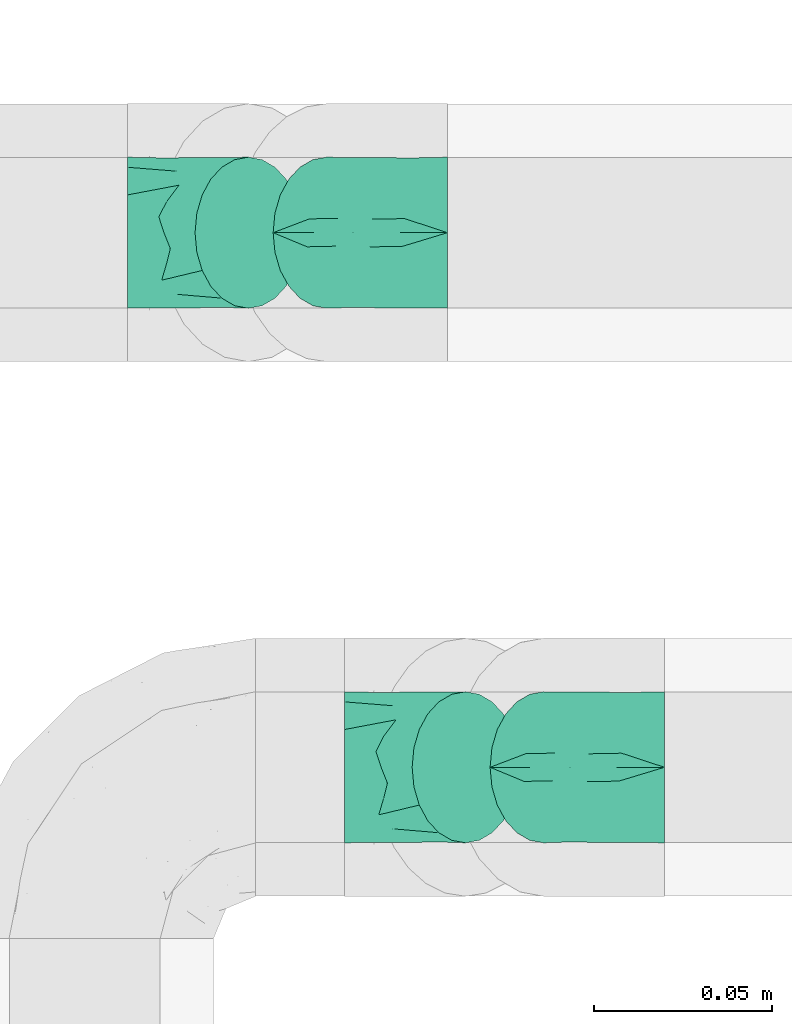
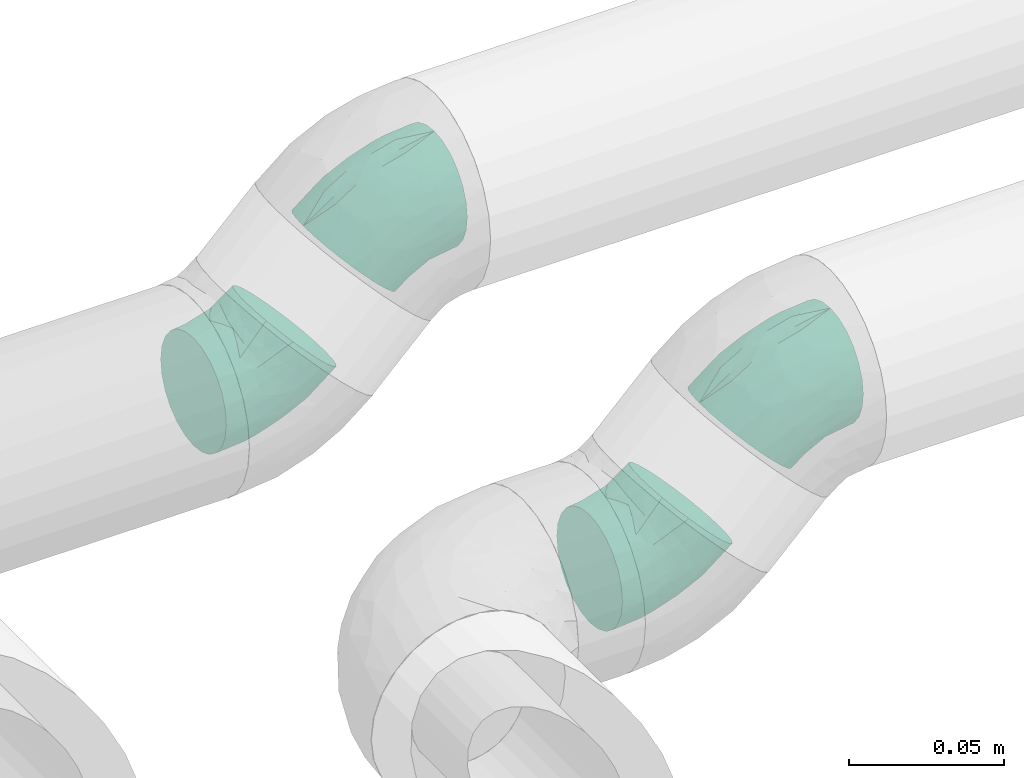
# One storey, part 38 of 39: 4 flow fittings.
"""IFC2X3 building model written with IfcOpenShell, lengths in millimetres."""

from ifc_helpers import new_model, entity, si_unit, converted_unit, derived_unit, direction, frame, origin, place, context, subcontext, project, spatial, faceted_brep, source, transform, mapped, material, type_object, type_shapes, element, save


model = new_model("IFC2X3")

# Units and contexts
model_context = context("Model", 3, precision=0.01, world=origin(), true_north=direction((6.12303176911189e-17, 1.0)))
body_context = subcontext(model_context, "Body", "Model", "MODEL_VIEW")
ifc_project = project(units=[si_unit("LENGTHUNIT", "METRE", prefix="MILLI"), si_unit("AREAUNIT", "SQUARE_METRE"), si_unit("VOLUMEUNIT", "CUBIC_METRE"), converted_unit("PLANEANGLEUNIT", "DEGREE", entity("IfcRatioMeasure", 0.0174532925199433), si_unit("PLANEANGLEUNIT", "RADIAN"), dimensions=[0, 0, 0, 0, 0, 0, 0]), si_unit("MASSUNIT", "GRAM", prefix="KILO"), derived_unit("MASSDENSITYUNIT", [(si_unit("MASSUNIT", "GRAM", prefix="KILO"), 1), (si_unit("LENGTHUNIT", "METRE"), -3)]), derived_unit("MOMENTOFINERTIAUNIT", [(si_unit("LENGTHUNIT", "METRE"), 4)]), si_unit("TIMEUNIT", "SECOND"), si_unit("FREQUENCYUNIT", "HERTZ"), si_unit("THERMODYNAMICTEMPERATUREUNIT", "DEGREE_CELSIUS"), derived_unit("THERMALTRANSMITTANCEUNIT", [(si_unit("MASSUNIT", "GRAM", prefix="KILO"), 1), (si_unit("THERMODYNAMICTEMPERATUREUNIT", "KELVIN"), -1), (si_unit("TIMEUNIT", "SECOND"), -3)]), derived_unit("VOLUMETRICFLOWRATEUNIT", [(si_unit("LENGTHUNIT", "METRE"), 3), (si_unit("TIMEUNIT", "SECOND"), -1)]), derived_unit("MASSFLOWRATEUNIT", [(si_unit("MASSUNIT", "GRAM", prefix="KILO"), 1), (si_unit("TIMEUNIT", "SECOND"), -1)]), derived_unit("ROTATIONALFREQUENCYUNIT", [(si_unit("TIMEUNIT", "SECOND"), -1)]), si_unit("ELECTRICCURRENTUNIT", "AMPERE"), si_unit("ELECTRICVOLTAGEUNIT", "VOLT"), si_unit("POWERUNIT", "WATT"), si_unit("FORCEUNIT", "NEWTON", prefix="KILO"), si_unit("ILLUMINANCEUNIT", "LUX"), si_unit("LUMINOUSFLUXUNIT", "LUMEN"), si_unit("LUMINOUSINTENSITYUNIT", "CANDELA"), derived_unit("USERDEFINED", [(si_unit("MASSUNIT", "GRAM", prefix="KILO"), -1), (si_unit("LENGTHUNIT", "METRE"), -2), (si_unit("TIMEUNIT", "SECOND"), 3), (si_unit("LUMINOUSFLUXUNIT", "LUMEN"), 1)]), derived_unit("LINEARVELOCITYUNIT", [(si_unit("LENGTHUNIT", "METRE"), 1), (si_unit("TIMEUNIT", "SECOND"), -1)]), si_unit("PRESSUREUNIT", "PASCAL"), derived_unit("USERDEFINED", [(si_unit("LENGTHUNIT", "METRE"), -2), (si_unit("MASSUNIT", "GRAM", prefix="KILO"), 1), (si_unit("TIMEUNIT", "SECOND"), -2)]), derived_unit("LINEARFORCEUNIT", [(si_unit("MASSUNIT", "GRAM", prefix="KILO"), 1), (si_unit("LENGTHUNIT", "METRE"), 1), (si_unit("TIMEUNIT", "SECOND"), -2), (si_unit("LENGTHUNIT", "METRE"), -1)]), derived_unit("PLANARFORCEUNIT", [(si_unit("MASSUNIT", "GRAM", prefix="KILO"), 1), (si_unit("LENGTHUNIT", "METRE"), 1), (si_unit("TIMEUNIT", "SECOND"), -2), (si_unit("LENGTHUNIT", "METRE"), -2)])], contexts=[model_context])

# Site, building, storey
site_placement = place(None, origin())
site = spatial("IfcSite", under=ifc_project, at=site_placement, CompositionType="ELEMENT")
building_placement = place(site_placement, origin())
building = spatial("IfcBuilding", under=site, at=building_placement, CompositionType="ELEMENT")
storey_placement = place(building_placement, frame((0.0, 0.0, 24000.0)))
storey = spatial("IfcBuildingStorey", under=building, at=storey_placement, Name="07", CompositionType="ELEMENT", Elevation=24000.0)

# Flow fittings
ifc_material = material()
pipe_fitting_type_1 = type_object("IfcPipeFittingType", Name="ADSK_1", PredefinedType="NOTDEFINED", material=ifc_material)
shared_shape_1 = source(origin(), body_context, "Body", "Brep", [
    faceted_brep([(-19.88, 10.6, -18.36), (-19.88, 5.49, -20.48), (-19.88, 0.0, -21.2), (-19.88, -5.49, -20.48), (-19.88, -10.6, -18.36), (-19.88, -14.99, -14.99), (-19.88, -18.36, -10.6), (-19.88, -20.48, -5.49), (-19.88, -21.2, 0.0), (-19.88, -20.48, 5.49), (-19.88, -18.36, 10.6), (-19.88, -14.99, 14.99), (-19.88, -10.6, 18.36), (-19.88, -5.49, 20.48), (-19.88, 0.0, 21.2), (-19.88, 5.49, 20.48), (-19.88, 10.6, 18.36), (-19.88, 14.99, 14.99), (-19.88, 18.36, 10.6), (-19.88, 20.48, 5.49), (-19.88, 21.2, 0.0), (-19.88, 20.48, -5.49), (-19.88, 18.36, -10.6), (-19.88, 14.99, -14.99), (14.06, 14.06, -21.2), (10.18, 17.94, -20.48), (6.56, 21.55, -18.36), (3.46, 24.66, -14.99), (1.08, 27.04, -10.6), (-0.42, 28.54, -5.49), (-0.93, 29.05, 0.0), (-0.42, 28.54, 5.49), (1.08, 27.04, 10.6), (3.46, 24.66, 14.99), (6.56, 21.55, 18.36), (10.18, 17.94, 20.48), (14.06, 14.06, 21.2), (17.94, 10.18, 20.48), (21.55, 6.56, 18.36), (24.66, 3.46, 14.99), (27.04, 1.08, 10.6), (28.54, -0.42, 5.49), (29.05, -0.93, 0.0), (28.54, -0.42, -5.49), (27.04, 1.08, -10.6), (24.66, 3.46, -14.99), (21.55, 6.56, -18.36), (17.94, 10.18, -20.48), (-7.98, -16.04, 12.48), (1.95, -4.7, 19.17), (-9.77, -7.63, 19.4), (-5.58, -11.73, 16.42), (16.99, -5.7, 12.48), (-7.22, -1.78, 20.93), (-9.05, 9.07, 19.79), (-2.24, 5.4, 21.12), (-11.98, 3.07, 21.07), (1.16, 13.58, 19.77), (4.62, 11.03, 20.88), (-4.7, -18.12, 7.46), (5.18, -12.51, 11.97), (12.3, 1.51, 19.4), (-8.92, 21.52, 8.68), (-10.28, 17.98, 13.33), (-6.22, 15.02, 17.27), (11.52, -13.28, 3.78), (6.03, -14.57, 7.78), (1.86, -17.3, 3.96), (-6.64, -18.57, 0.0), (-6.99, -19.62, 3.9), (19.51, -8.44, 3.96), (16.13, -9.49, 7.46), (-7.85, 23.53, 4.44), (-3.2, 19.54, 14.97), (6.36, 3.85, 20.93), (12.24, -4.35, 16.42), (6.6, -15.93, 0.0), (-9.63, 23.24, 0.0), (3.3, -7.97, 17.06), (17.82, -8.43, 0.0), (-7.22, -1.78, -20.93), (1.24, -17.54, -3.78), (6.03, -14.57, -7.78), (10.92, -13.55, -3.96), (-0.01, 12.81, -19.79), (-10.42, 8.78, -19.77), (-11.06, 4.53, -20.88), (-5.45, 19.99, -13.33), (-11.55, 16.08, -14.97), (12.24, -4.35, -16.42), (16.13, -9.49, -7.46), (-11.09, 22.19, -4.44), (-8.92, 21.52, -8.68), (6.36, 3.85, -20.93), (-7.83, -19.76, -3.96), (-4.7, -18.12, -7.46), (-7.98, -16.04, -12.48), (5.18, -12.51, -11.97), (-5.58, -11.73, -16.42), (3.3, -7.97, -17.06), (-9.77, -7.63, -19.4), (1.95, -4.7, -19.17), (-6.22, 15.02, -17.27), (18.82, -8.93, -3.9), (6.3, 10.64, -21.07), (12.3, 1.51, -19.4), (16.99, -5.7, -12.48), (-2.24, 5.4, -21.12)], [[[0, 1, 2, 3, 4, 5, 6, 7, 8, 9, 10, 11, 12, 13, 14, 15, 16, 17, 18, 19, 20, 21, 22, 23]], [[24, 25, 26, 27, 28, 29, 30, 31, 32, 33, 34, 35, 36, 37, 38, 39, 40, 41, 42, 43, 44, 45, 46, 47]], [[10, 48, 11]], [[49, 50, 51]], [[12, 11, 51]], [[40, 39, 52]], [[14, 13, 53]], [[13, 12, 50]], [[16, 15, 54]], [[55, 56, 53]], [[14, 56, 15]], [[35, 57, 58]], [[48, 59, 60]], [[38, 37, 61]], [[62, 18, 63]], [[64, 17, 16]], [[65, 66, 67]], [[68, 67, 69]], [[70, 71, 65]], [[62, 72, 19]], [[10, 9, 59]], [[20, 19, 72]], [[19, 18, 62]], [[48, 51, 11]], [[54, 64, 16]], [[59, 66, 60]], [[8, 68, 69]], [[33, 73, 34]], [[36, 58, 74]], [[39, 38, 75]], [[49, 74, 53]], [[74, 37, 36]], [[67, 68, 76]], [[71, 40, 52]], [[55, 58, 57]], [[75, 38, 61]], [[59, 48, 10]], [[65, 71, 66]], [[41, 70, 42]], [[56, 54, 15]], [[72, 62, 31]], [[77, 72, 30]], [[52, 75, 60]], [[51, 78, 49]], [[49, 61, 74]], [[35, 34, 57]], [[32, 31, 62]], [[62, 63, 32]], [[50, 53, 13]], [[32, 63, 73]], [[64, 54, 57]], [[18, 17, 63]], [[55, 53, 74]], [[41, 40, 71]], [[51, 48, 60]], [[78, 60, 75]], [[75, 52, 39]], [[71, 52, 60]], [[17, 64, 63]], [[73, 63, 64]], [[64, 57, 34]], [[55, 57, 54]], [[51, 50, 12]], [[53, 50, 49]], [[74, 61, 37]], [[75, 61, 49]], [[74, 58, 55]], [[36, 35, 58]], [[53, 56, 14]], [[54, 56, 55]], [[67, 66, 59]], [[71, 60, 66]], [[67, 59, 69]], [[67, 76, 65]], [[76, 79, 65]], [[70, 65, 79]], [[42, 70, 79]], [[41, 71, 70]], [[59, 9, 69]], [[8, 69, 9]], [[60, 78, 51]], [[75, 49, 78]], [[30, 72, 31]], [[72, 77, 20]], [[34, 73, 64]], [[32, 73, 33]], [[3, 2, 80]], [[81, 82, 83]], [[26, 25, 84]], [[1, 85, 86]], [[87, 88, 22]], [[46, 45, 89]], [[0, 23, 88]], [[44, 43, 90]], [[21, 91, 92]], [[24, 47, 93]], [[94, 95, 81]], [[1, 0, 85]], [[81, 95, 82]], [[95, 96, 97]], [[7, 94, 8]], [[96, 95, 6]], [[5, 4, 98]], [[99, 97, 98]], [[7, 6, 95]], [[5, 96, 6]], [[100, 4, 3]], [[28, 27, 87]], [[83, 79, 76]], [[89, 99, 101]], [[20, 77, 91]], [[98, 96, 5]], [[30, 29, 91]], [[29, 28, 92]], [[22, 92, 87]], [[92, 22, 21]], [[28, 87, 92]], [[100, 98, 4]], [[84, 102, 26]], [[102, 84, 85]], [[86, 80, 2]], [[27, 26, 102]], [[79, 83, 103]], [[24, 104, 25]], [[105, 47, 46]], [[90, 82, 97]], [[106, 89, 45]], [[89, 101, 105]], [[90, 97, 106]], [[101, 80, 93]], [[42, 79, 103]], [[101, 100, 80]], [[107, 93, 80]], [[106, 45, 44]], [[96, 98, 97]], [[104, 93, 107]], [[104, 84, 25]], [[29, 92, 91]], [[107, 86, 85]], [[105, 93, 47]], [[90, 106, 44]], [[89, 106, 97]], [[27, 102, 87]], [[88, 87, 102]], [[102, 85, 0]], [[107, 85, 84]], [[80, 100, 3]], [[98, 100, 101]], [[89, 105, 46]], [[93, 105, 101]], [[80, 86, 107]], [[2, 1, 86]], [[93, 104, 24]], [[84, 104, 107]], [[83, 82, 90]], [[95, 97, 82]], [[83, 90, 103]], [[83, 76, 81]], [[76, 68, 81]], [[94, 81, 68]], [[8, 94, 68]], [[7, 95, 94]], [[90, 43, 103]], [[42, 103, 43]], [[97, 99, 89]], [[98, 101, 99]], [[20, 91, 21]], [[91, 77, 30]], [[0, 88, 102]], [[22, 88, 23]]]),
])
type_shapes(pipe_fitting_type_1, [shared_shape_1])
flow_fitting_1_placement = place(storey_placement, frame((68762.89, 2725.35, 3029.96), z_axis=(0.0, -1.0, 0.0), x_axis=(1.0, 0.0, 1.53605279146355e-05)))
element("IfcFlowFitting", 1, at=flow_fitting_1_placement, inside=storey, type_object=pipe_fitting_type_1, material=ifc_material, Name="ADSK_1", ObjectType="ADSK_1", context=body_context, shape_type="MappedRepresentation", body=[
    mapped(shared_shape_1, transform((0.0, 0.0, 0.0), scale=1.0)),
])
pipe_fitting_type_2 = type_object("IfcPipeFittingType", Name="ADSK_1", PredefinedType="NOTDEFINED", material=ifc_material)
shared_shape_2 = source(origin(), body_context, "Body", "Brep", [
    faceted_brep([(-19.88, 10.6, -18.36), (-19.88, 5.49, -20.48), (-19.88, 0.0, -21.2), (-19.88, -5.49, -20.48), (-19.88, -10.6, -18.36), (-19.88, -14.99, -14.99), (-19.88, -18.36, -10.6), (-19.88, -20.48, -5.49), (-19.88, -21.2, 0.0), (-19.88, -20.48, 5.49), (-19.88, -18.36, 10.6), (-19.88, -14.99, 14.99), (-19.88, -10.6, 18.36), (-19.88, -5.49, 20.48), (-19.88, 0.0, 21.2), (-19.88, 5.49, 20.48), (-19.88, 10.6, 18.36), (-19.88, 14.99, 14.99), (-19.88, 18.36, 10.6), (-19.88, 20.48, 5.49), (-19.88, 21.2, 0.0), (-19.88, 20.48, -5.49), (-19.88, 18.36, -10.6), (-19.88, 14.99, -14.99), (1.08, 27.04, -10.6), (-0.42, 28.54, -5.49), (-0.93, 29.05, 0.0), (-0.42, 28.54, 5.49), (1.08, 27.04, 10.6), (3.46, 24.66, 14.99), (6.56, 21.55, 18.36), (10.18, 17.94, 20.48), (14.06, 14.06, 21.2), (17.94, 10.17, 20.48), (21.55, 6.56, 18.36), (24.66, 3.45, 14.99), (27.04, 1.07, 10.6), (28.54, -0.43, 5.49), (29.05, -0.94, 0.0), (28.54, -0.43, -5.49), (27.04, 1.07, -10.6), (24.66, 3.45, -14.99), (21.55, 6.56, -18.36), (17.94, 10.17, -20.48), (14.06, 14.06, -21.2), (10.18, 17.94, -20.48), (6.56, 21.55, -18.36), (3.46, 24.66, -14.99), (-7.98, -16.04, 12.48), (1.95, -4.7, 19.17), (-9.77, -7.63, 19.4), (-5.58, -11.73, 16.42), (16.99, -5.7, 12.48), (-7.22, -1.78, 20.93), (-9.05, 9.07, 19.79), (-2.23, 5.4, 21.12), (-11.98, 3.07, 21.07), (1.16, 13.58, 19.77), (4.61, 11.03, 20.88), (-4.69, -18.12, 7.46), (5.18, -12.51, 11.97), (12.3, 1.51, 19.4), (-8.91, 21.52, 8.68), (-10.28, 17.98, 13.33), (-6.22, 15.02, 17.26), (11.53, -13.28, 3.78), (6.03, -14.57, 7.78), (1.86, -17.3, 3.96), (-6.64, -18.57, 0.0), (-6.99, -19.62, 3.9), (19.51, -8.44, 3.96), (16.13, -9.5, 7.46), (-7.85, 23.53, 4.44), (-3.2, 19.54, 14.97), (6.36, 3.85, 20.93), (12.23, -4.35, 16.42), (6.6, -15.93, 0.0), (-9.62, 23.24, 0.0), (3.3, -7.97, 17.06), (17.82, -8.44, 0.0), (-7.22, -1.78, -20.93), (1.24, -17.54, -3.78), (6.03, -14.57, -7.78), (10.92, -13.55, -3.96), (-0.01, 12.81, -19.79), (-10.42, 8.78, -19.77), (-11.06, 4.53, -20.88), (-5.45, 19.99, -13.33), (-11.55, 16.08, -14.97), (12.23, -4.35, -16.42), (16.13, -9.5, -7.46), (-11.09, 22.19, -4.44), (-8.91, 21.52, -8.68), (6.36, 3.85, -20.93), (-7.83, -19.76, -3.96), (-4.69, -18.12, -7.46), (-7.98, -16.04, -12.48), (5.18, -12.51, -11.97), (-5.58, -11.73, -16.42), (3.3, -7.97, -17.06), (-9.77, -7.63, -19.4), (1.95, -4.7, -19.17), (-6.22, 15.02, -17.26), (18.82, -8.93, -3.9), (6.3, 10.64, -21.07), (12.3, 1.51, -19.4), (16.99, -5.7, -12.48), (-2.23, 5.4, -21.12)], [[[0, 1, 2, 3, 4, 5, 6, 7, 8, 9, 10, 11, 12, 13, 14, 15, 16, 17, 18, 19, 20, 21, 22, 23]], [[24, 25, 26, 27, 28, 29, 30, 31, 32, 33, 34, 35, 36, 37, 38, 39, 40, 41, 42, 43, 44, 45, 46, 47]], [[10, 48, 11]], [[49, 50, 51]], [[12, 11, 51]], [[36, 35, 52]], [[14, 13, 53]], [[13, 12, 50]], [[16, 15, 54]], [[55, 56, 53]], [[14, 56, 15]], [[31, 57, 58]], [[48, 59, 60]], [[34, 33, 61]], [[62, 18, 63]], [[64, 17, 16]], [[65, 66, 67]], [[68, 67, 69]], [[70, 71, 65]], [[62, 72, 19]], [[10, 9, 59]], [[20, 19, 72]], [[19, 18, 62]], [[48, 51, 11]], [[54, 64, 16]], [[59, 66, 60]], [[8, 68, 69]], [[29, 73, 30]], [[32, 58, 74]], [[35, 34, 75]], [[49, 74, 53]], [[74, 33, 32]], [[67, 68, 76]], [[71, 36, 52]], [[55, 58, 57]], [[75, 34, 61]], [[59, 48, 10]], [[65, 71, 66]], [[37, 70, 38]], [[56, 54, 15]], [[72, 62, 27]], [[77, 72, 26]], [[52, 75, 60]], [[51, 78, 49]], [[49, 61, 74]], [[31, 30, 57]], [[28, 27, 62]], [[62, 63, 28]], [[50, 53, 13]], [[28, 63, 73]], [[64, 54, 57]], [[18, 17, 63]], [[55, 53, 74]], [[37, 36, 71]], [[51, 48, 60]], [[78, 60, 75]], [[75, 52, 35]], [[71, 52, 60]], [[17, 64, 63]], [[73, 63, 64]], [[64, 57, 30]], [[55, 57, 54]], [[51, 50, 12]], [[53, 50, 49]], [[74, 61, 33]], [[75, 61, 49]], [[74, 58, 55]], [[32, 31, 58]], [[53, 56, 14]], [[54, 56, 55]], [[67, 66, 59]], [[71, 60, 66]], [[67, 59, 69]], [[67, 76, 65]], [[76, 79, 65]], [[70, 65, 79]], [[38, 70, 79]], [[37, 71, 70]], [[59, 9, 69]], [[8, 69, 9]], [[60, 78, 51]], [[75, 49, 78]], [[26, 72, 27]], [[72, 77, 20]], [[30, 73, 64]], [[28, 73, 29]], [[3, 2, 80]], [[81, 82, 83]], [[46, 45, 84]], [[1, 85, 86]], [[87, 88, 22]], [[42, 41, 89]], [[0, 23, 88]], [[40, 39, 90]], [[21, 91, 92]], [[44, 43, 93]], [[94, 95, 81]], [[1, 0, 85]], [[81, 95, 82]], [[95, 96, 97]], [[7, 94, 8]], [[96, 95, 6]], [[5, 4, 98]], [[99, 97, 98]], [[7, 6, 95]], [[5, 96, 6]], [[100, 4, 3]], [[24, 47, 87]], [[83, 79, 76]], [[89, 99, 101]], [[20, 77, 91]], [[98, 96, 5]], [[26, 25, 91]], [[25, 24, 92]], [[22, 92, 87]], [[92, 22, 21]], [[24, 87, 92]], [[100, 98, 4]], [[84, 102, 46]], [[102, 84, 85]], [[86, 80, 2]], [[47, 46, 102]], [[79, 83, 103]], [[44, 104, 45]], [[105, 43, 42]], [[90, 82, 97]], [[106, 89, 41]], [[89, 101, 105]], [[90, 97, 106]], [[101, 80, 93]], [[38, 79, 103]], [[101, 100, 80]], [[107, 93, 80]], [[106, 41, 40]], [[96, 98, 97]], [[104, 93, 107]], [[104, 84, 45]], [[25, 92, 91]], [[107, 86, 85]], [[105, 93, 43]], [[90, 106, 40]], [[89, 106, 97]], [[47, 102, 87]], [[88, 87, 102]], [[102, 85, 0]], [[107, 85, 84]], [[80, 100, 3]], [[98, 100, 101]], [[89, 105, 42]], [[93, 105, 101]], [[80, 86, 107]], [[2, 1, 86]], [[93, 104, 44]], [[84, 104, 107]], [[83, 82, 90]], [[95, 97, 82]], [[83, 90, 103]], [[83, 76, 81]], [[76, 68, 81]], [[94, 81, 68]], [[8, 94, 68]], [[7, 95, 94]], [[90, 39, 103]], [[38, 103, 39]], [[97, 99, 89]], [[98, 101, 99]], [[20, 91, 21]], [[91, 77, 26]], [[0, 88, 102]], [[22, 88, 23]]]),
])
type_shapes(pipe_fitting_type_2, [shared_shape_2])
flow_fitting_2_placement = place(storey_placement, frame((68752.01, 2875.35, 3080.0), z_axis=(0.0, -1.0, -2.11826697593205e-05), x_axis=(-1.0, 0.0, 0.0)))
element("IfcFlowFitting", 2, at=flow_fitting_2_placement, inside=storey, type_object=pipe_fitting_type_2, material=ifc_material, Name="ADSK_1", ObjectType="ADSK_1", context=body_context, shape_type="MappedRepresentation", body=[
    mapped(shared_shape_2, transform((0.0, 0.0, 0.0), scale=1.0)),
])
pipe_fitting_type_3 = type_object("IfcPipeFittingType", Name="ADSK_1", PredefinedType="NOTDEFINED", material=ifc_material)
shared_shape_3 = source(origin(), body_context, "Body", "Brep", [
    faceted_brep([(-19.89, 10.6, -18.36), (-19.89, 5.49, -20.48), (-19.89, 0.0, -21.2), (-19.89, -5.49, -20.48), (-19.89, -10.6, -18.36), (-19.89, -14.99, -14.99), (-19.89, -18.36, -10.6), (-19.89, -20.48, -5.49), (-19.89, -21.2, 0.0), (-19.89, -20.48, 5.49), (-19.89, -18.36, 10.6), (-19.89, -14.99, 14.99), (-19.89, -10.6, 18.36), (-19.89, -5.49, 20.48), (-19.89, 0.0, 21.2), (-19.89, 5.49, 20.48), (-19.89, 10.6, 18.36), (-19.89, 14.99, 14.99), (-19.89, 18.36, 10.6), (-19.89, 20.48, 5.49), (-19.89, 21.2, 0.0), (-19.89, 20.48, -5.49), (-19.89, 18.36, -10.6), (-19.89, 14.99, -14.99), (14.06, 14.06, -21.2), (10.18, 17.94, -20.48), (6.56, 21.56, -18.36), (3.46, 24.66, -14.99), (1.08, 27.04, -10.6), (-0.42, 28.54, -5.49), (-0.93, 29.05, 0.0), (-0.42, 28.54, 5.49), (1.08, 27.04, 10.6), (3.46, 24.66, 14.99), (6.56, 21.56, 18.36), (10.18, 17.94, 20.48), (14.06, 14.06, 21.2), (17.94, 10.18, 20.48), (21.56, 6.57, 18.36), (24.66, 3.46, 14.99), (27.04, 1.08, 10.6), (28.54, -0.42, 5.49), (29.05, -0.93, 0.0), (28.54, -0.42, -5.49), (27.04, 1.08, -10.6), (24.66, 3.46, -14.99), (21.56, 6.57, -18.36), (17.94, 10.18, -20.48), (-7.98, -16.04, 12.48), (1.95, -4.7, 19.17), (-9.77, -7.63, 19.4), (-5.58, -11.72, 16.42), (16.99, -5.7, 12.48), (-7.22, -1.78, 20.93), (-9.06, 9.07, 19.79), (-2.24, 5.4, 21.12), (-11.99, 3.07, 21.07), (1.16, 13.58, 19.77), (4.62, 11.03, 20.88), (-4.7, -18.12, 7.46), (5.18, -12.51, 11.97), (12.3, 1.52, 19.4), (-8.92, 21.52, 8.68), (-10.29, 17.98, 13.33), (-6.22, 15.02, 17.27), (11.52, -13.28, 3.78), (6.03, -14.57, 7.78), (1.85, -17.3, 3.96), (-6.64, -18.57, 0.0), (-6.99, -19.62, 3.9), (19.5, -8.44, 3.95), (16.14, -9.49, 7.46), (-7.85, 23.53, 4.44), (-3.2, 19.54, 14.97), (6.36, 3.85, 20.93), (12.24, -4.34, 16.42), (6.6, -15.93, 0.0), (-9.63, 23.24, 0.0), (3.3, -7.97, 17.06), (17.83, -8.43, 0.0), (-7.22, -1.78, -20.93), (1.25, -17.54, -3.78), (6.03, -14.57, -7.78), (10.93, -13.55, -3.96), (-0.01, 12.82, -19.79), (-10.42, 8.78, -19.77), (-11.06, 4.53, -20.88), (-5.45, 19.99, -13.33), (-11.56, 16.08, -14.97), (12.24, -4.34, -16.42), (16.14, -9.49, -7.46), (-11.09, 22.19, -4.44), (-8.92, 21.52, -8.68), (6.36, 3.85, -20.93), (-7.82, -19.76, -3.95), (-4.7, -18.12, -7.46), (-7.98, -16.04, -12.48), (5.18, -12.51, -11.97), (-5.58, -11.72, -16.42), (3.3, -7.97, -17.06), (-9.77, -7.63, -19.4), (1.95, -4.7, -19.17), (-6.22, 15.02, -17.27), (18.82, -8.93, -3.9), (6.3, 10.65, -21.07), (12.3, 1.52, -19.4), (16.99, -5.7, -12.48), (-2.24, 5.4, -21.12)], [[[0, 1, 2, 3, 4, 5, 6, 7, 8, 9, 10, 11, 12, 13, 14, 15, 16, 17, 18, 19, 20, 21, 22, 23]], [[24, 25, 26, 27, 28, 29, 30, 31, 32, 33, 34, 35, 36, 37, 38, 39, 40, 41, 42, 43, 44, 45, 46, 47]], [[10, 48, 11]], [[49, 50, 51]], [[12, 11, 51]], [[40, 39, 52]], [[14, 13, 53]], [[13, 12, 50]], [[16, 15, 54]], [[55, 56, 53]], [[14, 56, 15]], [[35, 57, 58]], [[48, 59, 60]], [[38, 37, 61]], [[62, 18, 63]], [[64, 17, 16]], [[65, 66, 67]], [[68, 67, 69]], [[70, 71, 65]], [[62, 72, 19]], [[10, 9, 59]], [[20, 19, 72]], [[19, 18, 62]], [[48, 51, 11]], [[54, 64, 16]], [[59, 66, 60]], [[8, 68, 69]], [[33, 73, 34]], [[36, 58, 74]], [[39, 38, 75]], [[49, 74, 53]], [[74, 37, 36]], [[67, 68, 76]], [[71, 40, 52]], [[55, 58, 57]], [[75, 38, 61]], [[59, 48, 10]], [[65, 71, 66]], [[41, 70, 42]], [[56, 54, 15]], [[72, 62, 31]], [[77, 72, 30]], [[52, 75, 60]], [[51, 78, 49]], [[49, 61, 74]], [[35, 34, 57]], [[32, 31, 62]], [[62, 63, 32]], [[50, 53, 13]], [[32, 63, 73]], [[64, 54, 57]], [[18, 17, 63]], [[55, 53, 74]], [[41, 40, 71]], [[51, 48, 60]], [[78, 60, 75]], [[75, 52, 39]], [[71, 52, 60]], [[17, 64, 63]], [[73, 63, 64]], [[64, 57, 34]], [[55, 57, 54]], [[51, 50, 12]], [[53, 50, 49]], [[74, 61, 37]], [[75, 61, 49]], [[74, 58, 55]], [[36, 35, 58]], [[53, 56, 14]], [[54, 56, 55]], [[67, 66, 59]], [[71, 60, 66]], [[67, 59, 69]], [[67, 76, 65]], [[76, 79, 65]], [[70, 65, 79]], [[42, 70, 79]], [[41, 71, 70]], [[59, 9, 69]], [[8, 69, 9]], [[60, 78, 51]], [[75, 49, 78]], [[30, 72, 31]], [[72, 77, 20]], [[34, 73, 64]], [[32, 73, 33]], [[3, 2, 80]], [[81, 82, 83]], [[26, 25, 84]], [[1, 85, 86]], [[87, 88, 22]], [[46, 45, 89]], [[0, 23, 88]], [[44, 43, 90]], [[21, 91, 92]], [[24, 47, 93]], [[94, 95, 81]], [[1, 0, 85]], [[81, 95, 82]], [[95, 96, 97]], [[7, 94, 8]], [[96, 95, 6]], [[5, 4, 98]], [[99, 97, 98]], [[7, 6, 95]], [[5, 96, 6]], [[100, 4, 3]], [[28, 27, 87]], [[83, 79, 76]], [[89, 99, 101]], [[20, 77, 91]], [[98, 96, 5]], [[30, 29, 91]], [[29, 28, 92]], [[22, 92, 87]], [[92, 22, 21]], [[28, 87, 92]], [[100, 98, 4]], [[84, 102, 26]], [[102, 84, 85]], [[86, 80, 2]], [[27, 26, 102]], [[79, 83, 103]], [[24, 104, 25]], [[105, 47, 46]], [[90, 82, 97]], [[106, 89, 45]], [[89, 101, 105]], [[90, 97, 106]], [[101, 80, 93]], [[42, 79, 103]], [[101, 100, 80]], [[107, 93, 80]], [[106, 45, 44]], [[96, 98, 97]], [[104, 93, 107]], [[104, 84, 25]], [[29, 92, 91]], [[107, 86, 85]], [[105, 93, 47]], [[90, 106, 44]], [[89, 106, 97]], [[27, 102, 87]], [[88, 87, 102]], [[102, 85, 0]], [[107, 85, 84]], [[80, 100, 3]], [[98, 100, 101]], [[89, 105, 46]], [[93, 105, 101]], [[80, 86, 107]], [[2, 1, 86]], [[93, 104, 24]], [[84, 104, 107]], [[83, 82, 90]], [[95, 97, 82]], [[83, 90, 103]], [[83, 76, 81]], [[76, 68, 81]], [[94, 81, 68]], [[8, 94, 68]], [[7, 95, 94]], [[90, 43, 103]], [[42, 103, 43]], [[97, 99, 89]], [[98, 101, 99]], [[20, 91, 21]], [[91, 77, 30]], [[0, 88, 102]], [[22, 88, 23]]]),
])
type_shapes(pipe_fitting_type_3, [shared_shape_3])
flow_fitting_3_placement = place(storey_placement, frame((68701.97, 2875.35, 3029.97), z_axis=(2.11779484984438e-05, 1.0, 0.0), x_axis=(-0.707185586519068, 1.49767399077523e-05, -0.707027966911762)))
element("IfcFlowFitting", 3, at=flow_fitting_3_placement, inside=storey, type_object=pipe_fitting_type_3, material=ifc_material, Name="ADSK_1", ObjectType="ADSK_1", context=body_context, shape_type="MappedRepresentation", body=[
    mapped(shared_shape_3, transform((0.0, 0.0, 0.0), scale=1.0)),
])
pipe_fitting_type_4 = type_object("IfcPipeFittingType", Name="ADSK_1", PredefinedType="NOTDEFINED", material=ifc_material)
shared_shape_4 = source(origin(), body_context, "Body", "Brep", [
    faceted_brep([(-19.88, 10.6, -18.36), (-19.88, 5.49, -20.48), (-19.88, 0.0, -21.2), (-19.88, -5.49, -20.48), (-19.88, -10.6, -18.36), (-19.88, -14.99, -14.99), (-19.88, -18.36, -10.6), (-19.88, -20.48, -5.49), (-19.88, -21.2, 0.0), (-19.88, -20.48, 5.49), (-19.88, -18.36, 10.6), (-19.88, -14.99, 14.99), (-19.88, -10.6, 18.36), (-19.88, -5.49, 20.48), (-19.88, 0.0, 21.2), (-19.88, 5.49, 20.48), (-19.88, 10.6, 18.36), (-19.88, 14.99, 14.99), (-19.88, 18.36, 10.6), (-19.88, 20.48, 5.49), (-19.88, 21.2, 0.0), (-19.88, 20.48, -5.49), (-19.88, 18.36, -10.6), (-19.88, 14.99, -14.99), (-0.42, 28.54, -5.49), (-0.93, 29.05, 0.0), (-0.42, 28.54, 5.49), (1.08, 27.04, 10.6), (3.46, 24.66, 14.99), (6.56, 21.55, 18.36), (10.18, 17.94, 20.48), (14.06, 14.06, 21.2), (17.94, 10.18, 20.48), (21.55, 6.56, 18.36), (24.66, 3.46, 14.99), (27.04, 1.08, 10.6), (28.54, -0.42, 5.49), (29.05, -0.93, 0.0), (28.54, -0.42, -5.49), (27.04, 1.08, -10.6), (24.66, 3.46, -14.99), (21.55, 6.56, -18.36), (17.94, 10.18, -20.48), (14.06, 14.06, -21.2), (10.18, 17.94, -20.48), (6.56, 21.55, -18.36), (3.46, 24.66, -14.99), (1.08, 27.04, -10.6), (-7.98, -16.04, 12.48), (1.95, -4.7, 19.17), (-9.77, -7.63, 19.4), (-5.58, -11.73, 16.42), (16.99, -5.7, 12.48), (-7.22, -1.78, 20.93), (-9.05, 9.07, 19.79), (-2.24, 5.4, 21.12), (-11.98, 3.07, 21.07), (1.16, 13.58, 19.77), (4.62, 11.03, 20.88), (-4.7, -18.12, 7.46), (5.18, -12.51, 11.97), (12.3, 1.51, 19.4), (-8.92, 21.52, 8.68), (-10.28, 17.98, 13.33), (-6.22, 15.02, 17.27), (11.52, -13.28, 3.78), (6.03, -14.57, 7.78), (1.86, -17.3, 3.96), (-6.64, -18.57, 0.0), (-6.99, -19.62, 3.9), (19.51, -8.44, 3.96), (16.13, -9.49, 7.46), (-7.85, 23.53, 4.44), (-3.2, 19.54, 14.97), (6.36, 3.85, 20.93), (12.24, -4.35, 16.42), (6.6, -15.93, 0.0), (-9.63, 23.24, 0.0), (3.3, -7.97, 17.06), (17.82, -8.43, 0.0), (-7.22, -1.78, -20.93), (1.24, -17.54, -3.78), (6.03, -14.57, -7.78), (10.92, -13.55, -3.96), (-0.01, 12.81, -19.79), (-10.42, 8.78, -19.77), (-11.06, 4.53, -20.88), (-5.45, 19.99, -13.33), (-11.55, 16.08, -14.97), (12.24, -4.35, -16.42), (16.13, -9.49, -7.46), (-11.09, 22.19, -4.44), (-8.92, 21.52, -8.68), (6.36, 3.85, -20.93), (-7.83, -19.76, -3.96), (-4.7, -18.12, -7.46), (-7.98, -16.04, -12.48), (5.18, -12.51, -11.97), (-5.58, -11.73, -16.42), (3.3, -7.97, -17.06), (-9.77, -7.63, -19.4), (1.95, -4.7, -19.17), (-6.22, 15.02, -17.27), (18.82, -8.93, -3.9), (6.3, 10.64, -21.07), (12.3, 1.51, -19.4), (16.99, -5.7, -12.48), (-2.24, 5.4, -21.12)], [[[0, 1, 2, 3, 4, 5, 6, 7, 8, 9, 10, 11, 12, 13, 14, 15, 16, 17, 18, 19, 20, 21, 22, 23]], [[24, 25, 26, 27, 28, 29, 30, 31, 32, 33, 34, 35, 36, 37, 38, 39, 40, 41, 42, 43, 44, 45, 46, 47]], [[10, 48, 11]], [[49, 50, 51]], [[12, 11, 51]], [[35, 34, 52]], [[14, 13, 53]], [[13, 12, 50]], [[16, 15, 54]], [[55, 56, 53]], [[14, 56, 15]], [[30, 57, 58]], [[48, 59, 60]], [[33, 32, 61]], [[62, 18, 63]], [[64, 17, 16]], [[65, 66, 67]], [[68, 67, 69]], [[70, 71, 65]], [[62, 72, 19]], [[10, 9, 59]], [[20, 19, 72]], [[19, 18, 62]], [[48, 51, 11]], [[54, 64, 16]], [[59, 66, 60]], [[8, 68, 69]], [[28, 73, 29]], [[31, 58, 74]], [[34, 33, 75]], [[49, 74, 53]], [[74, 32, 31]], [[67, 68, 76]], [[71, 35, 52]], [[55, 58, 57]], [[75, 33, 61]], [[59, 48, 10]], [[65, 71, 66]], [[36, 70, 37]], [[56, 54, 15]], [[72, 62, 26]], [[77, 72, 25]], [[52, 75, 60]], [[51, 78, 49]], [[49, 61, 74]], [[30, 29, 57]], [[27, 26, 62]], [[62, 63, 27]], [[50, 53, 13]], [[27, 63, 73]], [[64, 54, 57]], [[18, 17, 63]], [[55, 53, 74]], [[36, 35, 71]], [[51, 48, 60]], [[78, 60, 75]], [[75, 52, 34]], [[71, 52, 60]], [[17, 64, 63]], [[73, 63, 64]], [[64, 57, 29]], [[55, 57, 54]], [[51, 50, 12]], [[53, 50, 49]], [[74, 61, 32]], [[75, 61, 49]], [[74, 58, 55]], [[31, 30, 58]], [[53, 56, 14]], [[54, 56, 55]], [[67, 66, 59]], [[71, 60, 66]], [[67, 59, 69]], [[67, 76, 65]], [[76, 79, 65]], [[70, 65, 79]], [[37, 70, 79]], [[36, 71, 70]], [[59, 9, 69]], [[8, 69, 9]], [[60, 78, 51]], [[75, 49, 78]], [[25, 72, 26]], [[72, 77, 20]], [[29, 73, 64]], [[27, 73, 28]], [[3, 2, 80]], [[81, 82, 83]], [[45, 44, 84]], [[1, 85, 86]], [[87, 88, 22]], [[41, 40, 89]], [[0, 23, 88]], [[39, 38, 90]], [[21, 91, 92]], [[43, 42, 93]], [[94, 95, 81]], [[1, 0, 85]], [[81, 95, 82]], [[95, 96, 97]], [[7, 94, 8]], [[96, 95, 6]], [[5, 4, 98]], [[99, 97, 98]], [[7, 6, 95]], [[5, 96, 6]], [[100, 4, 3]], [[47, 46, 87]], [[83, 79, 76]], [[89, 99, 101]], [[20, 77, 91]], [[98, 96, 5]], [[25, 24, 91]], [[24, 47, 92]], [[22, 92, 87]], [[92, 22, 21]], [[47, 87, 92]], [[100, 98, 4]], [[84, 102, 45]], [[102, 84, 85]], [[86, 80, 2]], [[46, 45, 102]], [[79, 83, 103]], [[43, 104, 44]], [[105, 42, 41]], [[90, 82, 97]], [[106, 89, 40]], [[89, 101, 105]], [[90, 97, 106]], [[101, 80, 93]], [[37, 79, 103]], [[101, 100, 80]], [[107, 93, 80]], [[106, 40, 39]], [[96, 98, 97]], [[104, 93, 107]], [[104, 84, 44]], [[24, 92, 91]], [[107, 86, 85]], [[105, 93, 42]], [[90, 106, 39]], [[89, 106, 97]], [[46, 102, 87]], [[88, 87, 102]], [[102, 85, 0]], [[107, 85, 84]], [[80, 100, 3]], [[98, 100, 101]], [[89, 105, 41]], [[93, 105, 101]], [[80, 86, 107]], [[2, 1, 86]], [[93, 104, 43]], [[84, 104, 107]], [[83, 82, 90]], [[95, 97, 82]], [[83, 90, 103]], [[83, 76, 81]], [[76, 68, 81]], [[94, 81, 68]], [[8, 94, 68]], [[7, 95, 94]], [[90, 38, 103]], [[37, 103, 38]], [[97, 99, 89]], [[98, 101, 99]], [[20, 91, 21]], [[91, 77, 25]], [[0, 88, 102]], [[22, 88, 23]]]),
])
type_shapes(pipe_fitting_type_4, [shared_shape_4])
flow_fitting_4_placement = place(storey_placement, frame((68812.89, 2725.35, 3079.96), z_axis=(0.0, 1.0, 0.0), x_axis=(0.707101350398628, 0.0, 0.707112211932758)))
element("IfcFlowFitting", 4, at=flow_fitting_4_placement, inside=storey, type_object=pipe_fitting_type_4, material=ifc_material, Name="ADSK_1", ObjectType="ADSK_1", context=body_context, shape_type="MappedRepresentation", body=[
    mapped(shared_shape_4, transform((0.0, 0.0, 0.0), scale=1.0)),
])

save(model, "model.ifc")
